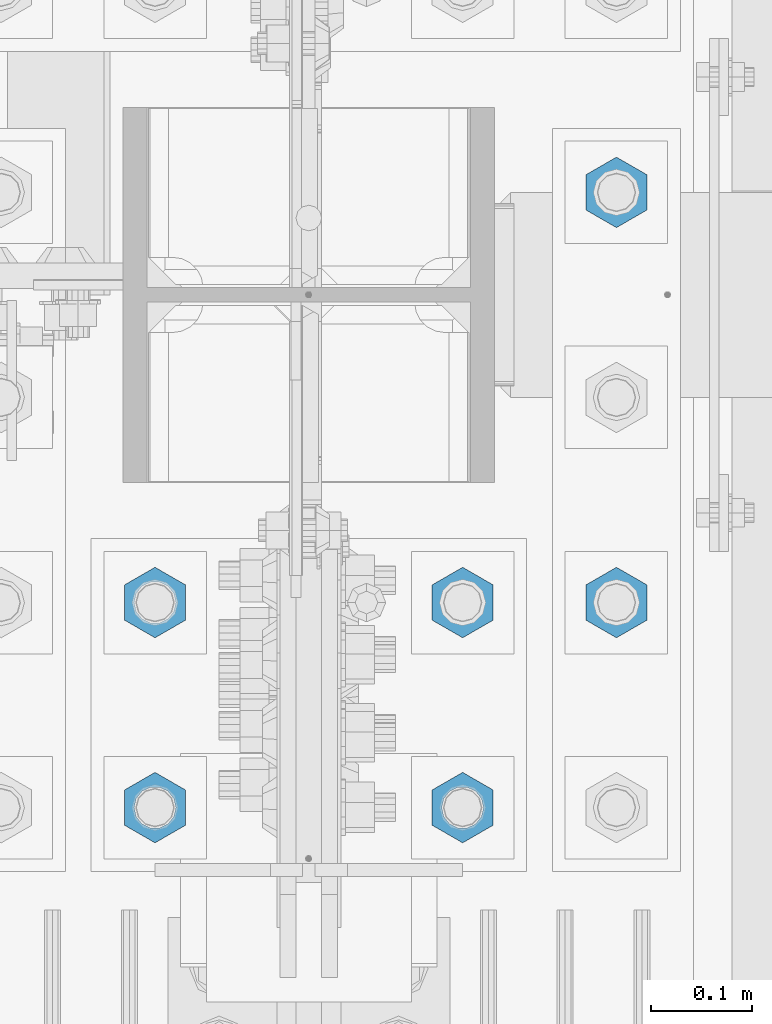
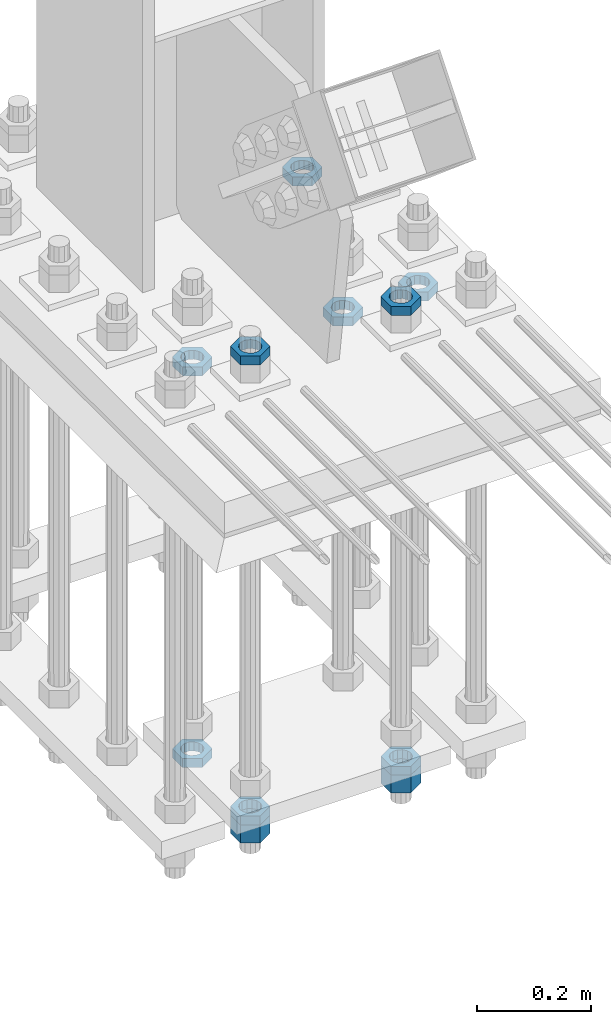
# One storey, part 2946 of 3843: 11 beams, 1 element without a shape of its own.
"""IFC2X3 building model written with IfcOpenShell, lengths in millimetres."""

from ifc_helpers import new_model, si_unit, frame, origin_with_axes, place, context, subcontext, project, spatial, faceted_brep, material, type_object, element, aggregate, save


model = new_model("IFC2X3")

# Units and contexts
model_context = context("Model", 3, precision=1e-05, world=origin_with_axes())
body_context = subcontext(model_context, "Body", "Model", "MODEL_VIEW")
ifc_project = project(units=[si_unit("LENGTHUNIT", "METRE", prefix="MILLI"), si_unit("AREAUNIT", "SQUARE_METRE"), si_unit("VOLUMEUNIT", "CUBIC_METRE"), si_unit("MASSUNIT", "GRAM", prefix="KILO"), si_unit("TIMEUNIT", "SECOND"), si_unit("PLANEANGLEUNIT", "RADIAN"), si_unit("SOLIDANGLEUNIT", "STERADIAN"), si_unit("THERMODYNAMICTEMPERATUREUNIT", "DEGREE_CELSIUS"), si_unit("LUMINOUSINTENSITYUNIT", "LUMEN")], contexts=[model_context])

# Site, building, storey
site_placement = place(None, origin_with_axes())
site = spatial("IfcSite", under=ifc_project, at=site_placement, CompositionType="ELEMENT")
building_placement = place(site_placement, origin_with_axes())
building = spatial("IfcBuilding", under=site, at=building_placement, Name="Undefined", CompositionType="ELEMENT")
storey_placement = place(building_placement, origin_with_axes())
storey = spatial("IfcBuildingStorey", under=building, at=storey_placement, Name="Undefined", CompositionType="ELEMENT", Elevation=0.0)

# Assembly, beams
assembly_placement = place(storey_placement, origin_with_axes())
assembly = element("IfcElementAssembly", 1, at=assembly_placement, inside=storey, Name="TEMPLATE", AssemblyPlace="NOTDEFINED", PredefinedType="RIGID_FRAME")
ifc_material = material(Name="STEEL/A572-50")
beam_type_1 = type_object("IfcBeamType", Name="1-1/2_HEAVY_HEX_NUT", PredefinedType="NOTDEFINED")
beam_1_placement = place(assembly_placement, frame((85801.2, 25107.9, 29203.6500015259), z_axis=(-1.0, 0.0, 0.0), x_axis=(0.0, 0.0, -1.0)))
beam_1 = element("IfcBeam", 2, at=beam_1_placement, type_object=beam_type_1, material=ifc_material, Name="NUT", ObjectType="1-1/2_HEAVY_HEX_NUT", context=body_context, shape_type="Brep", body=[
    faceted_brep([(0.0, -34.9199981689453, 0.0), (0.0, -17.4599990844727, -30.25), (38.0999999999985, -17.4599990844727, -30.25), (38.0999999999985, -34.9199981689453, 0.0), (0.0, 17.4599990844727, -30.25), (38.0999999999985, 17.4599990844727, -30.25), (0.0, 34.9199981689453, 0.0), (38.0999999999985, 34.9199981689453, 0.0), (0.0, 17.4599990844727, 30.25), (38.0999999999985, 17.4599990844727, 30.25), (0.0, -17.4599990844727, 30.25), (38.0999999999985, -17.4599990844727, 30.25), (0.0, 0.0, 20.6399993896484), (0.0, 8.9553601105581, 18.5959968835959), (38.0999999999985, 8.9553601105581, 18.5959968835959), (38.0999999999985, 0.0, 20.6399993896484), (0.0, 16.1370013209525, 12.8688291298167), (38.0999999999985, 16.1370013209525, 12.8688291298167), (0.0, 20.1225115123816, 4.59283194104501), (38.0999999999985, 20.1225115123816, 4.59283194104501), (0.0, 20.1225115123816, -4.59283194104501), (38.0999999999985, 20.1225115123816, -4.59283194104501), (0.0, 16.1370013209525, -12.8688291298167), (38.0999999999985, 16.1370013209525, -12.8688291298167), (0.0, 8.9553601105581, -18.5959968835959), (38.0999999999985, 8.9553601105581, -18.5959968835959), (0.0, 0.0, -20.6399993896484), (38.0999999999985, 0.0, -20.6399993896484), (0.0, -8.9553601105581, -18.5959968835959), (38.0999999999985, -8.9553601105581, -18.5959968835959), (0.0, -16.1370013209525, -12.8688291298167), (38.0999999999985, -16.1370013209525, -12.8688291298167), (0.0, -20.1225115123816, -4.59283194104501), (38.0999999999985, -20.1225115123816, -4.59283194104501), (0.0, -20.1225115123816, 4.59283194104501), (38.0999999999985, -20.1225115123816, 4.59283194104501), (0.0, -16.1370013209525, 12.8688291298167), (38.0999999999985, -16.1370013209525, 12.8688291298167), (0.0, -8.9553601105581, 18.5959968835959), (38.0999999999985, -8.9553601105581, 18.5959968835959)], [[[0, 1, 2, 3]], [[1, 4, 5, 2]], [[4, 6, 7, 5]], [[6, 8, 9, 7]], [[8, 10, 11, 9]], [[10, 0, 3, 11]], [[12, 13, 14, 15]], [[13, 16, 17, 14]], [[16, 18, 19, 17]], [[18, 20, 21, 19]], [[20, 22, 23, 21]], [[22, 24, 25, 23]], [[24, 26, 27, 25]], [[26, 28, 29, 27]], [[28, 30, 31, 29]], [[30, 32, 33, 31]], [[32, 34, 35, 33]], [[34, 36, 37, 35]], [[36, 38, 39, 37]], [[38, 12, 15, 39]], [[5, 7, 9, 11, 3, 2], [17, 19, 21, 23, 25, 27, 29, 31, 33, 35, 37, 39, 15, 14]], [[10, 8, 6, 4, 1, 0], [38, 36, 34, 32, 30, 28, 26, 24, 22, 20, 18, 16, 13, 12]]]),
])
beam_2_placement = place(assembly_placement, frame((85496.4, 25107.9, 29203.6500015259), z_axis=(-1.0, 0.0, 0.0), x_axis=(0.0, 0.0, -1.0)))
beam_2 = element("IfcBeam", 3, at=beam_2_placement, type_object=beam_type_1, material=ifc_material, Name="NUT", ObjectType="1-1/2_HEAVY_HEX_NUT", context=body_context, shape_type="Brep", body=[
    faceted_brep([(0.0, -34.9199981689453, 0.0), (0.0, -17.4599990844727, -30.25), (38.0999999999985, -17.4599990844727, -30.25), (38.0999999999985, -34.9199981689453, 0.0), (0.0, 17.4599990844727, -30.25), (38.0999999999985, 17.4599990844727, -30.25), (0.0, 34.9199981689453, 0.0), (38.0999999999985, 34.9199981689453, 0.0), (0.0, 17.4599990844727, 30.25), (38.0999999999985, 17.4599990844727, 30.25), (0.0, -17.4599990844727, 30.25), (38.0999999999985, -17.4599990844727, 30.25), (0.0, 0.0, 20.6399993896484), (0.0, 8.9553601105581, 18.5959968835959), (38.0999999999985, 8.9553601105581, 18.5959968835959), (38.0999999999985, 0.0, 20.6399993896484), (0.0, 16.1370013209525, 12.8688291298167), (38.0999999999985, 16.1370013209525, 12.8688291298167), (0.0, 20.1225115123816, 4.59283194104501), (38.0999999999985, 20.1225115123816, 4.59283194104501), (0.0, 20.1225115123816, -4.59283194104501), (38.0999999999985, 20.1225115123816, -4.59283194104501), (0.0, 16.1370013209525, -12.8688291298167), (38.0999999999985, 16.1370013209525, -12.8688291298167), (0.0, 8.9553601105581, -18.5959968835959), (38.0999999999985, 8.9553601105581, -18.5959968835959), (0.0, 0.0, -20.6399993896484), (38.0999999999985, 0.0, -20.6399993896484), (0.0, -8.9553601105581, -18.5959968835959), (38.0999999999985, -8.9553601105581, -18.5959968835959), (0.0, -16.1370013209525, -12.8688291298167), (38.0999999999985, -16.1370013209525, -12.8688291298167), (0.0, -20.1225115123816, -4.59283194104501), (38.0999999999985, -20.1225115123816, -4.59283194104501), (0.0, -20.1225115123816, 4.59283194104501), (38.0999999999985, -20.1225115123816, 4.59283194104501), (0.0, -16.1370013209525, 12.8688291298167), (38.0999999999985, -16.1370013209525, 12.8688291298167), (0.0, -8.9553601105581, 18.5959968835959), (38.0999999999985, -8.9553601105581, 18.5959968835959)], [[[0, 1, 2, 3]], [[1, 4, 5, 2]], [[4, 6, 7, 5]], [[6, 8, 9, 7]], [[8, 10, 11, 9]], [[10, 0, 3, 11]], [[12, 13, 14, 15]], [[13, 16, 17, 14]], [[16, 18, 19, 17]], [[18, 20, 21, 19]], [[20, 22, 23, 21]], [[22, 24, 25, 23]], [[24, 26, 27, 25]], [[26, 28, 29, 27]], [[28, 30, 31, 29]], [[30, 32, 33, 31]], [[32, 34, 35, 33]], [[34, 36, 37, 35]], [[36, 38, 39, 37]], [[38, 12, 15, 39]], [[5, 7, 9, 11, 3, 2], [17, 19, 21, 23, 25, 27, 29, 31, 33, 35, 37, 39, 15, 14]], [[10, 8, 6, 4, 1, 0], [38, 36, 34, 32, 30, 28, 26, 24, 22, 20, 18, 16, 13, 12]]]),
])
beam_type_2 = type_object("IfcBeamType", Name="1-1/2_HALF_NUT", PredefinedType="NOTDEFINED")
beam_3_placement = place(assembly_placement, frame((85953.6, 25311.1, 30060.9), z_axis=(-1.0, 0.0, 0.0), x_axis=(0.0, 0.0, -1.0)))
beam_3 = element("IfcBeam", 4, at=beam_3_placement, type_object=beam_type_2, material=ifc_material, Name="NUT", ObjectType="1-1/2_HALF_NUT", context=body_context, shape_type="Brep", body=[
    faceted_brep([(0.0, -34.9199981689453, 0.0), (0.0, -17.4599990844727, -30.25), (19.0500000000029, -17.4599990844727, -30.25), (19.0500000000029, -34.9199981689453, 0.0), (0.0, 17.4599990844727, -30.25), (19.0500000000029, 17.4599990844727, -30.25), (0.0, 34.9199981689453, 0.0), (19.0500000000029, 34.9199981689453, 0.0), (0.0, 17.4599990844727, 30.25), (19.0500000000029, 17.4599990844727, 30.25), (0.0, -17.4599990844727, 30.25), (19.0500000000029, -17.4599990844727, 30.25), (0.0, 0.0, 20.6399993896484), (0.0, 8.9553601105581, 18.5959968835959), (19.0500000000029, 8.95536011056538, 18.5959968835959), (19.0500000000029, 0.0, 20.6399993896484), (0.0, 16.1370013209525, 12.8688291298167), (19.0500000000029, 16.1370013209489, 12.8688291298167), (0.0, 20.1225115123816, 4.59283194104501), (19.0500000000029, 20.1225115123852, 4.59283194104501), (0.0, 20.1225115123816, -4.59283194104501), (19.0500000000029, 20.1225115123852, -4.59283194104501), (0.0, 16.1370013209525, -12.8688291298167), (19.0500000000029, 16.1370013209489, -12.8688291298167), (0.0, 8.9553601105581, -18.5959968835959), (19.0500000000029, 8.95536011056538, -18.5959968835959), (0.0, 0.0, -20.6399993896484), (19.0500000000029, 0.0, -20.6399993896484), (0.0, -8.9553601105581, -18.5959968835959), (19.0500000000029, -8.95536011056538, -18.5959968835959), (0.0, -16.1370013209525, -12.8688291298167), (19.0500000000029, -16.1370013209489, -12.8688291298167), (0.0, -20.1225115123816, -4.59283194104501), (19.0500000000029, -20.1225115123852, -4.59283194104501), (0.0, -20.1225115123816, 4.59283194104501), (19.0500000000029, -20.1225115123852, 4.59283194104501), (0.0, -16.1370013209525, 12.8688291298167), (19.0500000000029, -16.1370013209489, 12.8688291298167), (0.0, -8.9553601105581, 18.5959968835959), (19.0500000000029, -8.95536011056538, 18.5959968835959)], [[[0, 1, 2, 3]], [[1, 4, 5, 2]], [[4, 6, 7, 5]], [[6, 8, 9, 7]], [[8, 10, 11, 9]], [[10, 0, 3, 11]], [[12, 13, 14, 15]], [[13, 16, 17, 14]], [[16, 18, 19, 17]], [[18, 20, 21, 19]], [[20, 22, 23, 21]], [[22, 24, 25, 23]], [[24, 26, 27, 25]], [[26, 28, 29, 27]], [[28, 30, 31, 29]], [[30, 32, 33, 31]], [[32, 34, 35, 33]], [[34, 36, 37, 35]], [[36, 38, 39, 37]], [[38, 12, 15, 39]], [[5, 7, 9, 11, 3, 2], [17, 19, 21, 23, 25, 27, 29, 31, 33, 35, 37, 39, 15, 14]], [[10, 8, 6, 4, 1, 0], [38, 36, 34, 32, 30, 28, 26, 24, 22, 20, 18, 16, 13, 12]]]),
])
beam_4_placement = place(assembly_placement, frame((85953.6, 25717.5, 30060.9), z_axis=(1.0, 0.0, 0.0), x_axis=(0.0, 0.0, -1.0)))
beam_4 = element("IfcBeam", 5, at=beam_4_placement, type_object=beam_type_2, material=ifc_material, Name="NUT", ObjectType="1-1/2_HALF_NUT", context=body_context, shape_type="Brep", body=[
    faceted_brep([(0.0, -34.9199981689453, 0.0), (0.0, -17.4599990844727, -30.25), (19.0500000000029, -17.4599990844727, -30.25), (19.0500000000029, -34.9199981689453, 0.0), (0.0, 17.4599990844727, -30.25), (19.0500000000029, 17.4599990844727, -30.25), (0.0, 34.9199981689453, 0.0), (19.0500000000029, 34.9199981689453, 0.0), (0.0, 17.4599990844727, 30.25), (19.0500000000029, 17.4599990844727, 30.25), (0.0, -17.4599990844727, 30.25), (19.0500000000029, -17.4599990844727, 30.25), (0.0, 0.0, 20.6399993896484), (0.0, 8.9553601105581, 18.5959968835959), (19.0500000000029, 8.95536011056538, 18.5959968835959), (19.0500000000029, 0.0, 20.6399993896484), (0.0, 16.1370013209525, 12.8688291298167), (19.0500000000029, 16.1370013209489, 12.8688291298167), (0.0, 20.1225115123816, 4.59283194104501), (19.0500000000029, 20.1225115123852, 4.59283194104501), (0.0, 20.1225115123816, -4.59283194104501), (19.0500000000029, 20.1225115123852, -4.59283194104501), (0.0, 16.1370013209525, -12.8688291298167), (19.0500000000029, 16.1370013209489, -12.8688291298167), (0.0, 8.9553601105581, -18.5959968835959), (19.0500000000029, 8.95536011056538, -18.5959968835959), (0.0, 0.0, -20.6399993896484), (19.0500000000029, 0.0, -20.6399993896484), (0.0, -8.9553601105581, -18.5959968835959), (19.0500000000029, -8.95536011056538, -18.5959968835959), (0.0, -16.1370013209525, -12.8688291298167), (19.0500000000029, -16.1370013209489, -12.8688291298167), (0.0, -20.1225115123816, -4.59283194104501), (19.0500000000029, -20.1225115123852, -4.59283194104501), (0.0, -20.1225115123816, 4.59283194104501), (19.0500000000029, -20.1225115123852, 4.59283194104501), (0.0, -16.1370013209525, 12.8688291298167), (19.0500000000029, -16.1370013209489, 12.8688291298167), (0.0, -8.9553601105581, 18.5959968835959), (19.0500000000029, -8.95536011056538, 18.5959968835959)], [[[0, 1, 2, 3]], [[1, 4, 5, 2]], [[4, 6, 7, 5]], [[6, 8, 9, 7]], [[8, 10, 11, 9]], [[10, 0, 3, 11]], [[12, 13, 14, 15]], [[13, 16, 17, 14]], [[16, 18, 19, 17]], [[18, 20, 21, 19]], [[20, 22, 23, 21]], [[22, 24, 25, 23]], [[24, 26, 27, 25]], [[26, 28, 29, 27]], [[28, 30, 31, 29]], [[30, 32, 33, 31]], [[32, 34, 35, 33]], [[34, 36, 37, 35]], [[36, 38, 39, 37]], [[38, 12, 15, 39]], [[5, 7, 9, 11, 3, 2], [17, 19, 21, 23, 25, 27, 29, 31, 33, 35, 37, 39, 15, 14]], [[10, 8, 6, 4, 1, 0], [38, 36, 34, 32, 30, 28, 26, 24, 22, 20, 18, 16, 13, 12]]]),
])
beam_5_placement = place(assembly_placement, frame((85801.2, 25311.1, 30060.9), z_axis=(-1.0, 0.0, 0.0), x_axis=(0.0, 0.0, -1.0)))
beam_5 = element("IfcBeam", 6, at=beam_5_placement, type_object=beam_type_2, material=ifc_material, Name="NUT", ObjectType="1-1/2_HALF_NUT", context=body_context, shape_type="Brep", body=[
    faceted_brep([(0.0, -34.9199981689453, 0.0), (0.0, -17.4599990844727, -30.25), (19.0500000000029, -17.4599990844727, -30.25), (19.0500000000029, -34.9199981689453, 0.0), (0.0, 17.4599990844727, -30.25), (19.0500000000029, 17.4599990844727, -30.25), (0.0, 34.9199981689453, 0.0), (19.0500000000029, 34.9199981689453, 0.0), (0.0, 17.4599990844727, 30.25), (19.0500000000029, 17.4599990844727, 30.25), (0.0, -17.4599990844727, 30.25), (19.0500000000029, -17.4599990844727, 30.25), (0.0, 0.0, 20.6399993896484), (0.0, 8.9553601105581, 18.5959968835959), (19.0500000000029, 8.95536011056538, 18.5959968835959), (19.0500000000029, 0.0, 20.6399993896484), (0.0, 16.1370013209525, 12.8688291298167), (19.0500000000029, 16.1370013209489, 12.8688291298167), (0.0, 20.1225115123816, 4.59283194104501), (19.0500000000029, 20.1225115123852, 4.59283194104501), (0.0, 20.1225115123816, -4.59283194104501), (19.0500000000029, 20.1225115123852, -4.59283194104501), (0.0, 16.1370013209525, -12.8688291298167), (19.0500000000029, 16.1370013209489, -12.8688291298167), (0.0, 8.9553601105581, -18.5959968835959), (19.0500000000029, 8.95536011056538, -18.5959968835959), (0.0, 0.0, -20.6399993896484), (19.0500000000029, 0.0, -20.6399993896484), (0.0, -8.9553601105581, -18.5959968835959), (19.0500000000029, -8.95536011056538, -18.5959968835959), (0.0, -16.1370013209525, -12.8688291298167), (19.0500000000029, -16.1370013209489, -12.8688291298167), (0.0, -20.1225115123816, -4.59283194104501), (19.0500000000029, -20.1225115123852, -4.59283194104501), (0.0, -20.1225115123816, 4.59283194104501), (19.0500000000029, -20.1225115123852, 4.59283194104501), (0.0, -16.1370013209525, 12.8688291298167), (19.0500000000029, -16.1370013209489, 12.8688291298167), (0.0, -8.9553601105581, 18.5959968835959), (19.0500000000029, -8.95536011056538, 18.5959968835959)], [[[0, 1, 2, 3]], [[1, 4, 5, 2]], [[4, 6, 7, 5]], [[6, 8, 9, 7]], [[8, 10, 11, 9]], [[10, 0, 3, 11]], [[12, 13, 14, 15]], [[13, 16, 17, 14]], [[16, 18, 19, 17]], [[18, 20, 21, 19]], [[20, 22, 23, 21]], [[22, 24, 25, 23]], [[24, 26, 27, 25]], [[26, 28, 29, 27]], [[28, 30, 31, 29]], [[30, 32, 33, 31]], [[32, 34, 35, 33]], [[34, 36, 37, 35]], [[36, 38, 39, 37]], [[38, 12, 15, 39]], [[5, 7, 9, 11, 3, 2], [17, 19, 21, 23, 25, 27, 29, 31, 33, 35, 37, 39, 15, 14]], [[10, 8, 6, 4, 1, 0], [38, 36, 34, 32, 30, 28, 26, 24, 22, 20, 18, 16, 13, 12]]]),
])
beam_6_placement = place(assembly_placement, frame((85496.4, 25311.1, 30060.9), z_axis=(-1.0, 0.0, 0.0), x_axis=(0.0, 0.0, -1.0)))
beam_6 = element("IfcBeam", 7, at=beam_6_placement, type_object=beam_type_2, material=ifc_material, Name="NUT", ObjectType="1-1/2_HALF_NUT", context=body_context, shape_type="Brep", body=[
    faceted_brep([(0.0, -34.9199981689453, 0.0), (0.0, -17.4599990844727, -30.25), (19.0500000000029, -17.4599990844727, -30.25), (19.0500000000029, -34.9199981689453, 0.0), (0.0, 17.4599990844727, -30.25), (19.0500000000029, 17.4599990844727, -30.25), (0.0, 34.9199981689453, 0.0), (19.0500000000029, 34.9199981689453, 0.0), (0.0, 17.4599990844727, 30.25), (19.0500000000029, 17.4599990844727, 30.25), (0.0, -17.4599990844727, 30.25), (19.0500000000029, -17.4599990844727, 30.25), (0.0, 0.0, 20.6399993896484), (0.0, 8.9553601105581, 18.5959968835959), (19.0500000000029, 8.95536011056538, 18.5959968835959), (19.0500000000029, 0.0, 20.6399993896484), (0.0, 16.1370013209525, 12.8688291298167), (19.0500000000029, 16.1370013209489, 12.8688291298167), (0.0, 20.1225115123816, 4.59283194104501), (19.0500000000029, 20.1225115123852, 4.59283194104501), (0.0, 20.1225115123816, -4.59283194104501), (19.0500000000029, 20.1225115123852, -4.59283194104501), (0.0, 16.1370013209525, -12.8688291298167), (19.0500000000029, 16.1370013209489, -12.8688291298167), (0.0, 8.9553601105581, -18.5959968835959), (19.0500000000029, 8.95536011056538, -18.5959968835959), (0.0, 0.0, -20.6399993896484), (19.0500000000029, 0.0, -20.6399993896484), (0.0, -8.9553601105581, -18.5959968835959), (19.0500000000029, -8.95536011056538, -18.5959968835959), (0.0, -16.1370013209525, -12.8688291298167), (19.0500000000029, -16.1370013209489, -12.8688291298167), (0.0, -20.1225115123816, -4.59283194104501), (19.0500000000029, -20.1225115123852, -4.59283194104501), (0.0, -20.1225115123816, 4.59283194104501), (19.0500000000029, -20.1225115123852, 4.59283194104501), (0.0, -16.1370013209525, 12.8688291298167), (19.0500000000029, -16.1370013209489, 12.8688291298167), (0.0, -8.9553601105581, 18.5959968835959), (19.0500000000029, -8.95536011056538, 18.5959968835959)], [[[0, 1, 2, 3]], [[1, 4, 5, 2]], [[4, 6, 7, 5]], [[6, 8, 9, 7]], [[8, 10, 11, 9]], [[10, 0, 3, 11]], [[12, 13, 14, 15]], [[13, 16, 17, 14]], [[16, 18, 19, 17]], [[18, 20, 21, 19]], [[20, 22, 23, 21]], [[22, 24, 25, 23]], [[24, 26, 27, 25]], [[26, 28, 29, 27]], [[28, 30, 31, 29]], [[30, 32, 33, 31]], [[32, 34, 35, 33]], [[34, 36, 37, 35]], [[36, 38, 39, 37]], [[38, 12, 15, 39]], [[5, 7, 9, 11, 3, 2], [17, 19, 21, 23, 25, 27, 29, 31, 33, 35, 37, 39, 15, 14]], [[10, 8, 6, 4, 1, 0], [38, 36, 34, 32, 30, 28, 26, 24, 22, 20, 18, 16, 13, 12]]]),
])
beam_7_placement = place(assembly_placement, frame((85801.2, 25107.9, 29222.7000015259), z_axis=(-1.0, 0.0, 0.0), x_axis=(0.0, 0.0, -1.0)))
beam_7 = element("IfcBeam", 8, at=beam_7_placement, type_object=beam_type_2, material=ifc_material, Name="NUT", ObjectType="1-1/2_HALF_NUT", context=body_context, shape_type="Brep", body=[
    faceted_brep([(0.0, -34.9199981689453, 0.0), (0.0, -17.4599990844727, -30.25), (19.0500000000029, -17.4599990844727, -30.25), (19.0500000000029, -34.9199981689453, 0.0), (0.0, 17.4599990844727, -30.25), (19.0500000000029, 17.4599990844727, -30.25), (0.0, 34.9199981689453, 0.0), (19.0500000000029, 34.9199981689453, 0.0), (0.0, 17.4599990844727, 30.25), (19.0500000000029, 17.4599990844727, 30.25), (0.0, -17.4599990844727, 30.25), (19.0500000000029, -17.4599990844727, 30.25), (0.0, 0.0, 20.6399993896484), (0.0, 8.9553601105581, 18.5959968835959), (19.0500000000029, 8.95536011056538, 18.5959968835959), (19.0500000000029, 0.0, 20.6399993896484), (0.0, 16.1370013209525, 12.8688291298167), (19.0500000000029, 16.1370013209489, 12.8688291298167), (0.0, 20.1225115123816, 4.59283194104501), (19.0500000000029, 20.1225115123852, 4.59283194104501), (0.0, 20.1225115123816, -4.59283194104501), (19.0500000000029, 20.1225115123852, -4.59283194104501), (0.0, 16.1370013209525, -12.8688291298167), (19.0500000000029, 16.1370013209489, -12.8688291298167), (0.0, 8.9553601105581, -18.5959968835959), (19.0500000000029, 8.95536011056538, -18.5959968835959), (0.0, 0.0, -20.6399993896484), (19.0500000000029, 0.0, -20.6399993896484), (0.0, -8.9553601105581, -18.5959968835959), (19.0500000000029, -8.95536011056538, -18.5959968835959), (0.0, -16.1370013209525, -12.8688291298167), (19.0500000000029, -16.1370013209489, -12.8688291298167), (0.0, -20.1225115123816, -4.59283194104501), (19.0500000000029, -20.1225115123852, -4.59283194104501), (0.0, -20.1225115123816, 4.59283194104501), (19.0500000000029, -20.1225115123852, 4.59283194104501), (0.0, -16.1370013209525, 12.8688291298167), (19.0500000000029, -16.1370013209489, 12.8688291298167), (0.0, -8.9553601105581, 18.5959968835959), (19.0500000000029, -8.95536011056538, 18.5959968835959)], [[[0, 1, 2, 3]], [[1, 4, 5, 2]], [[4, 6, 7, 5]], [[6, 8, 9, 7]], [[8, 10, 11, 9]], [[10, 0, 3, 11]], [[12, 13, 14, 15]], [[13, 16, 17, 14]], [[16, 18, 19, 17]], [[18, 20, 21, 19]], [[20, 22, 23, 21]], [[22, 24, 25, 23]], [[24, 26, 27, 25]], [[26, 28, 29, 27]], [[28, 30, 31, 29]], [[30, 32, 33, 31]], [[32, 34, 35, 33]], [[34, 36, 37, 35]], [[36, 38, 39, 37]], [[38, 12, 15, 39]], [[5, 7, 9, 11, 3, 2], [17, 19, 21, 23, 25, 27, 29, 31, 33, 35, 37, 39, 15, 14]], [[10, 8, 6, 4, 1, 0], [38, 36, 34, 32, 30, 28, 26, 24, 22, 20, 18, 16, 13, 12]]]),
])
beam_8_placement = place(assembly_placement, frame((85801.2, 25107.9, 30206.95), z_axis=(-1.0, 0.0, 0.0), x_axis=(0.0, 0.0, -1.0)))
beam_8 = element("IfcBeam", 9, at=beam_8_placement, type_object=beam_type_2, material=ifc_material, Name="NUT", ObjectType="1-1/2_HALF_NUT", context=body_context, shape_type="Brep", body=[
    faceted_brep([(0.0, -34.9199981689453, 0.0), (0.0, -17.4599990844727, -30.25), (19.0500000000029, -17.4599990844727, -30.25), (19.0500000000029, -34.9199981689453, 0.0), (0.0, 17.4599990844727, -30.25), (19.0500000000029, 17.4599990844727, -30.25), (0.0, 34.9199981689453, 0.0), (19.0500000000029, 34.9199981689453, 0.0), (0.0, 17.4599990844727, 30.25), (19.0500000000029, 17.4599990844727, 30.25), (0.0, -17.4599990844727, 30.25), (19.0500000000029, -17.4599990844727, 30.25), (0.0, 0.0, 20.6399993896484), (0.0, 8.9553601105581, 18.5959968835959), (19.0500000000029, 8.95536011056538, 18.5959968835959), (19.0500000000029, 0.0, 20.6399993896484), (0.0, 16.1370013209525, 12.8688291298167), (19.0500000000029, 16.1370013209489, 12.8688291298167), (0.0, 20.1225115123816, 4.59283194104501), (19.0500000000029, 20.1225115123852, 4.59283194104501), (0.0, 20.1225115123816, -4.59283194104501), (19.0500000000029, 20.1225115123852, -4.59283194104501), (0.0, 16.1370013209525, -12.8688291298167), (19.0500000000029, 16.1370013209489, -12.8688291298167), (0.0, 8.9553601105581, -18.5959968835959), (19.0500000000029, 8.95536011056538, -18.5959968835959), (0.0, 0.0, -20.6399993896484), (19.0500000000029, 0.0, -20.6399993896484), (0.0, -8.9553601105581, -18.5959968835959), (19.0500000000029, -8.95536011056538, -18.5959968835959), (0.0, -16.1370013209525, -12.8688291298167), (19.0500000000029, -16.1370013209489, -12.8688291298167), (0.0, -20.1225115123816, -4.59283194104501), (19.0500000000029, -20.1225115123852, -4.59283194104501), (0.0, -20.1225115123816, 4.59283194104501), (19.0500000000029, -20.1225115123852, 4.59283194104501), (0.0, -16.1370013209525, 12.8688291298167), (19.0500000000029, -16.1370013209489, 12.8688291298167), (0.0, -8.9553601105581, 18.5959968835959), (19.0500000000029, -8.95536011056538, 18.5959968835959)], [[[0, 1, 2, 3]], [[1, 4, 5, 2]], [[4, 6, 7, 5]], [[6, 8, 9, 7]], [[8, 10, 11, 9]], [[10, 0, 3, 11]], [[12, 13, 14, 15]], [[13, 16, 17, 14]], [[16, 18, 19, 17]], [[18, 20, 21, 19]], [[20, 22, 23, 21]], [[22, 24, 25, 23]], [[24, 26, 27, 25]], [[26, 28, 29, 27]], [[28, 30, 31, 29]], [[30, 32, 33, 31]], [[32, 34, 35, 33]], [[34, 36, 37, 35]], [[36, 38, 39, 37]], [[38, 12, 15, 39]], [[5, 7, 9, 11, 3, 2], [17, 19, 21, 23, 25, 27, 29, 31, 33, 35, 37, 39, 15, 14]], [[10, 8, 6, 4, 1, 0], [38, 36, 34, 32, 30, 28, 26, 24, 22, 20, 18, 16, 13, 12]]]),
])
beam_9_placement = place(assembly_placement, frame((85496.4, 25107.9, 29222.7000015259), z_axis=(-1.0, 0.0, 0.0), x_axis=(0.0, 0.0, -1.0)))
beam_9 = element("IfcBeam", 10, at=beam_9_placement, type_object=beam_type_2, material=ifc_material, Name="NUT", ObjectType="1-1/2_HALF_NUT", context=body_context, shape_type="Brep", body=[
    faceted_brep([(0.0, -34.9199981689453, 0.0), (0.0, -17.4599990844727, -30.25), (19.0500000000029, -17.4599990844727, -30.25), (19.0500000000029, -34.9199981689453, 0.0), (0.0, 17.4599990844727, -30.25), (19.0500000000029, 17.4599990844727, -30.25), (0.0, 34.9199981689453, 0.0), (19.0500000000029, 34.9199981689453, 0.0), (0.0, 17.4599990844727, 30.25), (19.0500000000029, 17.4599990844727, 30.25), (0.0, -17.4599990844727, 30.25), (19.0500000000029, -17.4599990844727, 30.25), (0.0, 0.0, 20.6399993896484), (0.0, 8.9553601105581, 18.5959968835959), (19.0500000000029, 8.95536011056538, 18.5959968835959), (19.0500000000029, 0.0, 20.6399993896484), (0.0, 16.1370013209525, 12.8688291298167), (19.0500000000029, 16.1370013209489, 12.8688291298167), (0.0, 20.1225115123816, 4.59283194104501), (19.0500000000029, 20.1225115123852, 4.59283194104501), (0.0, 20.1225115123816, -4.59283194104501), (19.0500000000029, 20.1225115123852, -4.59283194104501), (0.0, 16.1370013209525, -12.8688291298167), (19.0500000000029, 16.1370013209489, -12.8688291298167), (0.0, 8.9553601105581, -18.5959968835959), (19.0500000000029, 8.95536011056538, -18.5959968835959), (0.0, 0.0, -20.6399993896484), (19.0500000000029, 0.0, -20.6399993896484), (0.0, -8.9553601105581, -18.5959968835959), (19.0500000000029, -8.95536011056538, -18.5959968835959), (0.0, -16.1370013209525, -12.8688291298167), (19.0500000000029, -16.1370013209489, -12.8688291298167), (0.0, -20.1225115123816, -4.59283194104501), (19.0500000000029, -20.1225115123852, -4.59283194104501), (0.0, -20.1225115123816, 4.59283194104501), (19.0500000000029, -20.1225115123852, 4.59283194104501), (0.0, -16.1370013209525, 12.8688291298167), (19.0500000000029, -16.1370013209489, 12.8688291298167), (0.0, -8.9553601105581, 18.5959968835959), (19.0500000000029, -8.95536011056538, 18.5959968835959)], [[[0, 1, 2, 3]], [[1, 4, 5, 2]], [[4, 6, 7, 5]], [[6, 8, 9, 7]], [[8, 10, 11, 9]], [[10, 0, 3, 11]], [[12, 13, 14, 15]], [[13, 16, 17, 14]], [[16, 18, 19, 17]], [[18, 20, 21, 19]], [[20, 22, 23, 21]], [[22, 24, 25, 23]], [[24, 26, 27, 25]], [[26, 28, 29, 27]], [[28, 30, 31, 29]], [[30, 32, 33, 31]], [[32, 34, 35, 33]], [[34, 36, 37, 35]], [[36, 38, 39, 37]], [[38, 12, 15, 39]], [[5, 7, 9, 11, 3, 2], [17, 19, 21, 23, 25, 27, 29, 31, 33, 35, 37, 39, 15, 14]], [[10, 8, 6, 4, 1, 0], [38, 36, 34, 32, 30, 28, 26, 24, 22, 20, 18, 16, 13, 12]]]),
])
beam_10_placement = place(assembly_placement, frame((85496.4, 25107.9, 30206.95), z_axis=(-1.0, 0.0, 0.0), x_axis=(0.0, 0.0, -1.0)))
beam_10 = element("IfcBeam", 11, at=beam_10_placement, type_object=beam_type_2, material=ifc_material, Name="NUT", ObjectType="1-1/2_HALF_NUT", context=body_context, shape_type="Brep", body=[
    faceted_brep([(0.0, -34.9199981689453, 0.0), (0.0, -17.4599990844727, -30.25), (19.0500000000029, -17.4599990844727, -30.25), (19.0500000000029, -34.9199981689453, 0.0), (0.0, 17.4599990844727, -30.25), (19.0500000000029, 17.4599990844727, -30.25), (0.0, 34.9199981689453, 0.0), (19.0500000000029, 34.9199981689453, 0.0), (0.0, 17.4599990844727, 30.25), (19.0500000000029, 17.4599990844727, 30.25), (0.0, -17.4599990844727, 30.25), (19.0500000000029, -17.4599990844727, 30.25), (0.0, 0.0, 20.6399993896484), (0.0, 8.9553601105581, 18.5959968835959), (19.0500000000029, 8.95536011056538, 18.5959968835959), (19.0500000000029, 0.0, 20.6399993896484), (0.0, 16.1370013209525, 12.8688291298167), (19.0500000000029, 16.1370013209489, 12.8688291298167), (0.0, 20.1225115123816, 4.59283194104501), (19.0500000000029, 20.1225115123852, 4.59283194104501), (0.0, 20.1225115123816, -4.59283194104501), (19.0500000000029, 20.1225115123852, -4.59283194104501), (0.0, 16.1370013209525, -12.8688291298167), (19.0500000000029, 16.1370013209489, -12.8688291298167), (0.0, 8.9553601105581, -18.5959968835959), (19.0500000000029, 8.95536011056538, -18.5959968835959), (0.0, 0.0, -20.6399993896484), (19.0500000000029, 0.0, -20.6399993896484), (0.0, -8.9553601105581, -18.5959968835959), (19.0500000000029, -8.95536011056538, -18.5959968835959), (0.0, -16.1370013209525, -12.8688291298167), (19.0500000000029, -16.1370013209489, -12.8688291298167), (0.0, -20.1225115123816, -4.59283194104501), (19.0500000000029, -20.1225115123852, -4.59283194104501), (0.0, -20.1225115123816, 4.59283194104501), (19.0500000000029, -20.1225115123852, 4.59283194104501), (0.0, -16.1370013209525, 12.8688291298167), (19.0500000000029, -16.1370013209489, 12.8688291298167), (0.0, -8.9553601105581, 18.5959968835959), (19.0500000000029, -8.95536011056538, 18.5959968835959)], [[[0, 1, 2, 3]], [[1, 4, 5, 2]], [[4, 6, 7, 5]], [[6, 8, 9, 7]], [[8, 10, 11, 9]], [[10, 0, 3, 11]], [[12, 13, 14, 15]], [[13, 16, 17, 14]], [[16, 18, 19, 17]], [[18, 20, 21, 19]], [[20, 22, 23, 21]], [[22, 24, 25, 23]], [[24, 26, 27, 25]], [[26, 28, 29, 27]], [[28, 30, 31, 29]], [[30, 32, 33, 31]], [[32, 34, 35, 33]], [[34, 36, 37, 35]], [[36, 38, 39, 37]], [[38, 12, 15, 39]], [[5, 7, 9, 11, 3, 2], [17, 19, 21, 23, 25, 27, 29, 31, 33, 35, 37, 39, 15, 14]], [[10, 8, 6, 4, 1, 0], [38, 36, 34, 32, 30, 28, 26, 24, 22, 20, 18, 16, 13, 12]]]),
])
beam_11_placement = place(assembly_placement, frame((85496.4, 25311.1, 29222.7000015259), z_axis=(-1.0, 0.0, 0.0), x_axis=(0.0, 0.0, -1.0)))
beam_11 = element("IfcBeam", 12, at=beam_11_placement, type_object=beam_type_2, material=ifc_material, Name="NUT", ObjectType="1-1/2_HALF_NUT", context=body_context, shape_type="Brep", body=[
    faceted_brep([(0.0, -34.9199981689453, 0.0), (0.0, -17.4599990844727, -30.25), (19.0500000000029, -17.4599990844727, -30.25), (19.0500000000029, -34.9199981689453, 0.0), (0.0, 17.4599990844727, -30.25), (19.0500000000029, 17.4599990844727, -30.25), (0.0, 34.9199981689453, 0.0), (19.0500000000029, 34.9199981689453, 0.0), (0.0, 17.4599990844727, 30.25), (19.0500000000029, 17.4599990844727, 30.25), (0.0, -17.4599990844727, 30.25), (19.0500000000029, -17.4599990844727, 30.25), (0.0, 0.0, 20.6399993896484), (0.0, 8.9553601105581, 18.5959968835959), (19.0500000000029, 8.95536011056538, 18.5959968835959), (19.0500000000029, 0.0, 20.6399993896484), (0.0, 16.1370013209525, 12.8688291298167), (19.0500000000029, 16.1370013209489, 12.8688291298167), (0.0, 20.1225115123816, 4.59283194104501), (19.0500000000029, 20.1225115123852, 4.59283194104501), (0.0, 20.1225115123816, -4.59283194104501), (19.0500000000029, 20.1225115123852, -4.59283194104501), (0.0, 16.1370013209525, -12.8688291298167), (19.0500000000029, 16.1370013209489, -12.8688291298167), (0.0, 8.9553601105581, -18.5959968835959), (19.0500000000029, 8.95536011056538, -18.5959968835959), (0.0, 0.0, -20.6399993896484), (19.0500000000029, 0.0, -20.6399993896484), (0.0, -8.9553601105581, -18.5959968835959), (19.0500000000029, -8.95536011056538, -18.5959968835959), (0.0, -16.1370013209525, -12.8688291298167), (19.0500000000029, -16.1370013209489, -12.8688291298167), (0.0, -20.1225115123816, -4.59283194104501), (19.0500000000029, -20.1225115123852, -4.59283194104501), (0.0, -20.1225115123816, 4.59283194104501), (19.0500000000029, -20.1225115123852, 4.59283194104501), (0.0, -16.1370013209525, 12.8688291298167), (19.0500000000029, -16.1370013209489, 12.8688291298167), (0.0, -8.9553601105581, 18.5959968835959), (19.0500000000029, -8.95536011056538, 18.5959968835959)], [[[0, 1, 2, 3]], [[1, 4, 5, 2]], [[4, 6, 7, 5]], [[6, 8, 9, 7]], [[8, 10, 11, 9]], [[10, 0, 3, 11]], [[12, 13, 14, 15]], [[13, 16, 17, 14]], [[16, 18, 19, 17]], [[18, 20, 21, 19]], [[20, 22, 23, 21]], [[22, 24, 25, 23]], [[24, 26, 27, 25]], [[26, 28, 29, 27]], [[28, 30, 31, 29]], [[30, 32, 33, 31]], [[32, 34, 35, 33]], [[34, 36, 37, 35]], [[36, 38, 39, 37]], [[38, 12, 15, 39]], [[5, 7, 9, 11, 3, 2], [17, 19, 21, 23, 25, 27, 29, 31, 33, 35, 37, 39, 15, 14]], [[10, 8, 6, 4, 1, 0], [38, 36, 34, 32, 30, 28, 26, 24, 22, 20, 18, 16, 13, 12]]]),
])
aggregate(assembly, [beam_3, beam_4, beam_5, beam_6, beam_7, beam_1, beam_8, beam_9, beam_2, beam_10, beam_11])

save(model, "model.ifc")
